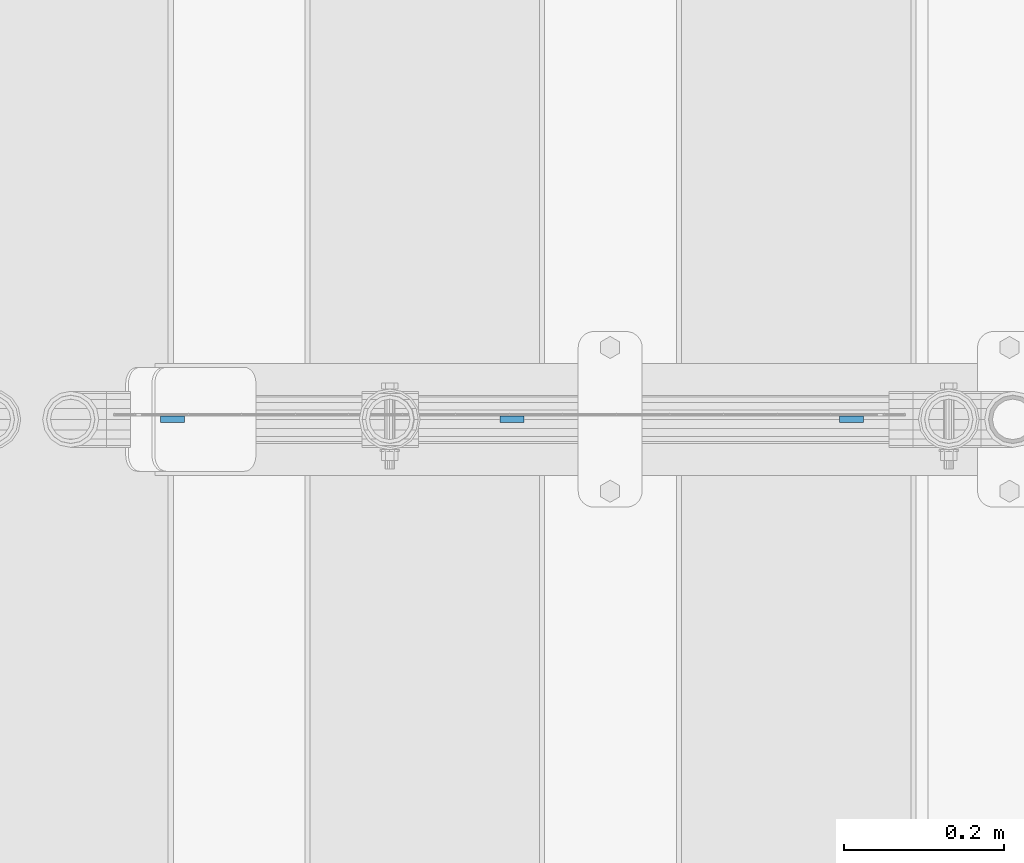
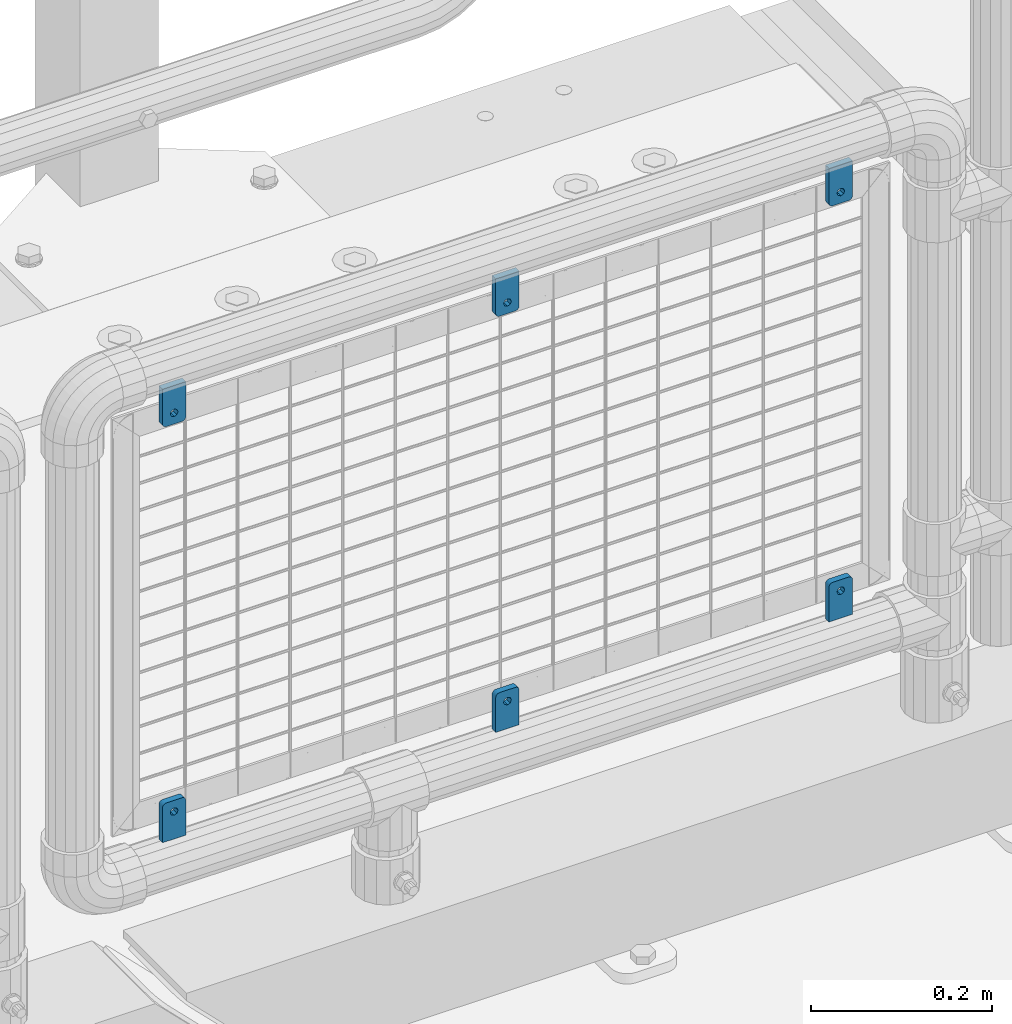
# One storey, part 244 of 247: 6 plates.
"""IFC2X3 building model written with IfcOpenShell, lengths in millimetres."""

from ifc_helpers import new_model, si_unit, frame, origin_with_axes, place, context, subcontext, project, spatial, faceted_brep, material, type_object, element, save


model = new_model("IFC2X3")

# Units and contexts
model_context = context("Model", 3, precision=1e-05, world=origin_with_axes())
body_context = subcontext(model_context, "Body", "Model", "MODEL_VIEW")
ifc_project = project(units=[si_unit("LENGTHUNIT", "METRE", prefix="MILLI"), si_unit("AREAUNIT", "SQUARE_METRE"), si_unit("VOLUMEUNIT", "CUBIC_METRE"), si_unit("MASSUNIT", "GRAM", prefix="KILO"), si_unit("TIMEUNIT", "SECOND"), si_unit("PLANEANGLEUNIT", "RADIAN"), si_unit("SOLIDANGLEUNIT", "STERADIAN"), si_unit("THERMODYNAMICTEMPERATUREUNIT", "DEGREE_CELSIUS"), si_unit("LUMINOUSINTENSITYUNIT", "LUMEN")], contexts=[model_context])

# Site, building, storey
site_placement = place(None, origin_with_axes())
site = spatial("IfcSite", under=ifc_project, at=site_placement, CompositionType="ELEMENT")
building_placement = place(site_placement, origin_with_axes())
building = spatial("IfcBuilding", under=site, at=building_placement, Name="Standard", CompositionType="ELEMENT")
storey_placement = place(building_placement, origin_with_axes())
storey = spatial("IfcBuildingStorey", under=building, at=storey_placement, Name="Undefined", CompositionType="ELEMENT", Elevation=0.0)

# Plates
ifc_material = material(Name="STEEL/S355J2")
plate_type = type_object("IfcPlateType", PredefinedType="NOTDEFINED")
plate_1_placement = place(storey_placement, frame((15689.1, 7664.49994161967, 328.320000000077), z_axis=(-1.0, 0.0, 0.0), x_axis=(0.0, 0.0, 1.0)))
element("IfcPlate", 1, at=plate_1_placement, inside=storey, type_object=plate_type, material=ifc_material, context=body_context, shape_type="Brep", body=[
    faceted_brep([(48.5450849718748, -3.99999999999909, 29.7552825814757), (49.9389262614624, -3.99999999999909, 29.0450849718746), (49.9389262614624, 4.00000000000091, 29.0450849718746), (48.5450849718748, 4.00000000000091, 29.7552825814757), (51.0450849718748, -4.0, 27.9389262614624), (51.0450849718748, 4.0, 27.9389262614623), (51.7552825814757, -4.0, 26.5450849718746), (51.7552825814757, 4.0, 26.5450849718746), (52.0, -4.0, 25.0), (52.0, 4.0, 24.9999999999999), (52.0, -4.0, 5.0), (52.0, 4.0, 4.99999999999989), (51.7552825814757, -4.0, 3.45491502812524), (51.7552825814757, 4.0, 3.45491502812524), (51.0450849718748, -4.0, 2.06107373853763), (51.0450849718748, 4.0, 2.06107373853752), (49.9389262614624, -4.0, 0.954915028125242), (49.9389262614624, 4.0, 0.954915028125242), (48.5450849718748, -4.0, 0.244717418524147), (48.5450849718748, 4.0, 0.244717418524147), (47.0, -4.0, 0.0), (47.0, 4.0, -1.13686837721616e-13), (0.0, -4.0, 0.0), (0.0, 4.0, -1.13686837721616e-13), (0.0, -3.99999999999909, 30.0), (47.0, -3.99999999999909, 30.0), (47.0, 4.00000000000091, 29.9999999999999), (0.0, 4.00000000000091, 29.9999999999999), (42.0, -4.0, 15.0000000039363), (40.5355339059328, -4.0, 11.4644660980035), (37.0, -4.0, 10.0000000039363), (33.4644660940672, -4.0, 11.4644660980035), (32.0, -4.0, 15.0000000039363), (33.4644660940672, -4.0, 18.5355339098691), (37.0, -4.0, 20.0000000039363), (40.5355339059328, -4.0, 18.5355339098691), (33.4644660940672, 4.00000000000091, 11.4644660900035), (37.0, 4.00000000000091, 9.99999999593626), (32.0, 4.00000000000091, 14.9999999959363), (33.4644660940672, 4.00000000000091, 18.535533901869), (37.0, 4.00000000000091, 19.9999999959363), (40.5355339059328, 4.00000000000091, 18.535533901869), (42.0, 4.00000000000091, 14.9999999959363), (40.5355339059328, 4.00000000000091, 11.4644660900035)], [[[0, 1, 2, 3]], [[1, 4, 5, 2]], [[4, 6, 7, 5]], [[6, 8, 9, 7]], [[8, 10, 11, 9]], [[10, 12, 13, 11]], [[12, 14, 15, 13]], [[14, 16, 17, 15]], [[16, 18, 19, 17]], [[18, 20, 21, 19]], [[20, 22, 23, 21]], [[24, 25, 26, 27]], [[22, 24, 27, 23]], [[20, 18, 16, 14, 12, 10, 8, 6, 4, 1, 0, 25, 24, 22], [28, 29, 30, 31, 32, 33, 34, 35]], [[36, 31, 30, 37]], [[38, 32, 31, 36]], [[39, 33, 32, 38]], [[40, 34, 33, 39]], [[41, 35, 34, 40]], [[42, 28, 35, 41]], [[43, 29, 28, 42]], [[37, 30, 29, 43]], [[26, 3, 2, 5, 7, 9, 11, 13, 15, 17, 19, 21, 23, 27], [38, 36, 37, 43, 42, 41, 40, 39]], [[25, 0, 3, 26]]]),
])
plate_2_placement = place(storey_placement, frame((15659.1, 7664.49994161967, 939.699999999924), z_axis=(1.0, 0.0, 0.0), x_axis=(0.0, 0.0, -1.0)))
element("IfcPlate", 2, at=plate_2_placement, inside=storey, type_object=plate_type, material=ifc_material, context=body_context, shape_type="Brep", body=[
    faceted_brep([(48.5450849718748, -3.99999999999909, 29.7552825814757), (49.9389262614624, -3.99999999999909, 29.0450849718746), (49.9389262614624, 4.00000000000091, 29.0450849718746), (48.5450849718748, 4.00000000000091, 29.7552825814757), (51.0450849718748, -4.0, 27.9389262614624), (51.0450849718748, 4.0, 27.9389262614623), (51.7552825814757, -4.0, 26.5450849718746), (51.7552825814757, 4.0, 26.5450849718746), (52.0, -4.0, 25.0), (52.0, 4.0, 24.9999999999999), (52.0, -4.0, 5.0), (52.0, 4.0, 4.99999999999989), (51.7552825814757, -4.0, 3.45491502812524), (51.7552825814757, 4.0, 3.45491502812524), (51.0450849718748, -4.0, 2.06107373853763), (51.0450849718748, 4.0, 2.06107373853752), (49.9389262614624, -4.0, 0.954915028125242), (49.9389262614624, 4.0, 0.954915028125242), (48.5450849718748, -4.0, 0.244717418524147), (48.5450849718748, 4.0, 0.244717418524147), (47.0, -4.0, 0.0), (47.0, 4.0, -1.13686837721616e-13), (0.0, -4.0, 0.0), (0.0, 4.0, -1.13686837721616e-13), (0.0, -3.99999999999909, 30.0), (47.0, -3.99999999999909, 30.0), (47.0, 4.00000000000091, 29.9999999999999), (0.0, 4.00000000000091, 29.9999999999999), (42.0, -4.0, 15.0000000039363), (40.5355339059328, -4.0, 11.4644660980035), (37.0, -4.0, 10.0000000039363), (33.4644660940672, -4.0, 11.4644660980035), (32.0, -4.0, 15.0000000039363), (33.4644660940672, -4.0, 18.5355339098691), (37.0, -4.0, 20.0000000039363), (40.5355339059328, -4.0, 18.5355339098691), (40.5355339059328, 4.00000000000091, 18.535533901869), (37.0, 4.00000000000091, 19.9999999959363), (42.0, 4.00000000000091, 14.9999999959363), (40.5355339059328, 4.00000000000091, 11.4644660900035), (37.0, 4.00000000000091, 9.99999999593626), (33.4644660940672, 4.00000000000091, 11.4644660900035), (32.0, 4.00000000000091, 14.9999999959363), (33.4644660940672, 4.00000000000091, 18.535533901869)], [[[0, 1, 2, 3]], [[1, 4, 5, 2]], [[4, 6, 7, 5]], [[6, 8, 9, 7]], [[8, 10, 11, 9]], [[10, 12, 13, 11]], [[12, 14, 15, 13]], [[14, 16, 17, 15]], [[16, 18, 19, 17]], [[18, 20, 21, 19]], [[20, 22, 23, 21]], [[24, 25, 26, 27]], [[22, 24, 27, 23]], [[20, 18, 16, 14, 12, 10, 8, 6, 4, 1, 0, 25, 24, 22], [28, 29, 30, 31, 32, 33, 34, 35]], [[36, 35, 34, 37]], [[38, 28, 35, 36]], [[39, 29, 28, 38]], [[40, 30, 29, 39]], [[41, 31, 30, 40]], [[42, 32, 31, 41]], [[43, 33, 32, 42]], [[37, 34, 33, 43]], [[26, 3, 2, 5, 7, 9, 11, 13, 15, 17, 19, 21, 23, 27], [42, 41, 40, 39, 38, 36, 37, 43]], [[25, 0, 3, 26]]]),
])
plate_3_placement = place(storey_placement, frame((15264.1, 7664.49994161967, 328.320000000077), z_axis=(-1.0, 0.0, 0.0), x_axis=(0.0, 0.0, 1.0)))
element("IfcPlate", 3, at=plate_3_placement, inside=storey, type_object=plate_type, material=ifc_material, context=body_context, shape_type="Brep", body=[
    faceted_brep([(48.5450849718748, -3.99999999999909, 29.7552825814757), (49.9389262614624, -3.99999999999909, 29.0450849718746), (49.9389262614624, 4.00000000000091, 29.0450849718746), (48.5450849718748, 4.00000000000091, 29.7552825814757), (51.0450849718748, -4.0, 27.9389262614624), (51.0450849718748, 4.0, 27.9389262614623), (51.7552825814757, -4.0, 26.5450849718746), (51.7552825814757, 4.0, 26.5450849718746), (52.0, -4.0, 25.0), (52.0, 4.0, 24.9999999999999), (52.0, -4.0, 5.0), (52.0, 4.0, 4.99999999999989), (51.7552825814757, -4.0, 3.45491502812524), (51.7552825814757, 4.0, 3.45491502812524), (51.0450849718748, -4.0, 2.06107373853763), (51.0450849718748, 4.0, 2.06107373853752), (49.9389262614624, -4.0, 0.954915028125242), (49.9389262614624, 4.0, 0.954915028125242), (48.5450849718748, -4.0, 0.244717418524147), (48.5450849718748, 4.0, 0.244717418524147), (47.0, -4.0, 0.0), (47.0, 4.0, -1.13686837721616e-13), (0.0, -4.0, 0.0), (0.0, 4.0, -1.13686837721616e-13), (0.0, -3.99999999999909, 30.0), (47.0, -3.99999999999909, 30.0), (47.0, 4.00000000000091, 29.9999999999999), (0.0, 4.00000000000091, 29.9999999999999), (42.0, -4.0, 15.0000000039363), (40.5355339059328, -4.0, 11.4644660980035), (37.0, -4.0, 10.0000000039363), (33.4644660940672, -4.0, 11.4644660980035), (32.0, -4.0, 15.0000000039363), (33.4644660940672, -4.0, 18.5355339098691), (37.0, -4.0, 20.0000000039363), (40.5355339059328, -4.0, 18.5355339098691), (33.4644660940672, 4.00000000000091, 11.4644660900035), (37.0, 4.00000000000091, 9.99999999593626), (32.0, 4.00000000000091, 14.9999999959363), (33.4644660940672, 4.00000000000091, 18.535533901869), (37.0, 4.00000000000091, 19.9999999959363), (40.5355339059328, 4.00000000000091, 18.535533901869), (42.0, 4.00000000000091, 14.9999999959363), (40.5355339059328, 4.00000000000091, 11.4644660900035)], [[[0, 1, 2, 3]], [[1, 4, 5, 2]], [[4, 6, 7, 5]], [[6, 8, 9, 7]], [[8, 10, 11, 9]], [[10, 12, 13, 11]], [[12, 14, 15, 13]], [[14, 16, 17, 15]], [[16, 18, 19, 17]], [[18, 20, 21, 19]], [[20, 22, 23, 21]], [[24, 25, 26, 27]], [[22, 24, 27, 23]], [[20, 18, 16, 14, 12, 10, 8, 6, 4, 1, 0, 25, 24, 22], [28, 29, 30, 31, 32, 33, 34, 35]], [[36, 31, 30, 37]], [[38, 32, 31, 36]], [[39, 33, 32, 38]], [[40, 34, 33, 39]], [[41, 35, 34, 40]], [[42, 28, 35, 41]], [[43, 29, 28, 42]], [[37, 30, 29, 43]], [[26, 3, 2, 5, 7, 9, 11, 13, 15, 17, 19, 21, 23, 27], [38, 36, 37, 43, 42, 41, 40, 39]], [[25, 0, 3, 26]]]),
])
plate_4_placement = place(storey_placement, frame((15234.1, 7664.49994161967, 939.699999999924), z_axis=(1.0, 0.0, 0.0), x_axis=(0.0, 0.0, -1.0)))
element("IfcPlate", 4, at=plate_4_placement, inside=storey, type_object=plate_type, material=ifc_material, context=body_context, shape_type="Brep", body=[
    faceted_brep([(48.5450849718748, -3.99999999999909, 29.7552825814757), (49.9389262614624, -3.99999999999909, 29.0450849718746), (49.9389262614624, 4.00000000000091, 29.0450849718746), (48.5450849718748, 4.00000000000091, 29.7552825814757), (51.0450849718748, -4.0, 27.9389262614624), (51.0450849718748, 4.0, 27.9389262614623), (51.7552825814757, -4.0, 26.5450849718746), (51.7552825814757, 4.0, 26.5450849718746), (52.0, -4.0, 25.0), (52.0, 4.0, 24.9999999999999), (52.0, -4.0, 5.0), (52.0, 4.0, 4.99999999999989), (51.7552825814757, -4.0, 3.45491502812524), (51.7552825814757, 4.0, 3.45491502812524), (51.0450849718748, -4.0, 2.06107373853763), (51.0450849718748, 4.0, 2.06107373853752), (49.9389262614624, -4.0, 0.954915028125242), (49.9389262614624, 4.0, 0.954915028125242), (48.5450849718748, -4.0, 0.244717418524147), (48.5450849718748, 4.0, 0.244717418524147), (47.0, -4.0, 0.0), (47.0, 4.0, -1.13686837721616e-13), (0.0, -4.0, 0.0), (0.0, 4.0, -1.13686837721616e-13), (0.0, -3.99999999999909, 30.0), (47.0, -3.99999999999909, 30.0), (47.0, 4.00000000000091, 29.9999999999999), (0.0, 4.00000000000091, 29.9999999999999), (42.0, -4.0, 15.0000000039363), (40.5355339059328, -4.0, 11.4644660980035), (37.0, -4.0, 10.0000000039363), (33.4644660940672, -4.0, 11.4644660980035), (32.0, -4.0, 15.0000000039363), (33.4644660940672, -4.0, 18.5355339098691), (37.0, -4.0, 20.0000000039363), (40.5355339059328, -4.0, 18.5355339098691), (40.5355339059328, 4.00000000000091, 18.535533901869), (37.0, 4.00000000000091, 19.9999999959363), (42.0, 4.00000000000091, 14.9999999959363), (40.5355339059328, 4.00000000000091, 11.4644660900035), (37.0, 4.00000000000091, 9.99999999593626), (33.4644660940672, 4.00000000000091, 11.4644660900035), (32.0, 4.00000000000091, 14.9999999959363), (33.4644660940672, 4.00000000000091, 18.535533901869)], [[[0, 1, 2, 3]], [[1, 4, 5, 2]], [[4, 6, 7, 5]], [[6, 8, 9, 7]], [[8, 10, 11, 9]], [[10, 12, 13, 11]], [[12, 14, 15, 13]], [[14, 16, 17, 15]], [[16, 18, 19, 17]], [[18, 20, 21, 19]], [[20, 22, 23, 21]], [[24, 25, 26, 27]], [[22, 24, 27, 23]], [[20, 18, 16, 14, 12, 10, 8, 6, 4, 1, 0, 25, 24, 22], [28, 29, 30, 31, 32, 33, 34, 35]], [[36, 35, 34, 37]], [[38, 28, 35, 36]], [[39, 29, 28, 38]], [[40, 30, 29, 39]], [[41, 31, 30, 40]], [[42, 32, 31, 41]], [[43, 33, 32, 42]], [[37, 34, 33, 43]], [[26, 3, 2, 5, 7, 9, 11, 13, 15, 17, 19, 21, 23, 27], [42, 41, 40, 39, 38, 36, 37, 43]], [[25, 0, 3, 26]]]),
])
plate_5_placement = place(storey_placement, frame((16114.1, 7664.49994161967, 328.320000000077), z_axis=(-1.0, 0.0, 0.0), x_axis=(0.0, 0.0, 1.0)))
element("IfcPlate", 5, at=plate_5_placement, inside=storey, type_object=plate_type, material=ifc_material, context=body_context, shape_type="Brep", body=[
    faceted_brep([(48.5450849718748, -3.99999999999909, 29.7552825814757), (49.9389262614624, -3.99999999999909, 29.0450849718746), (49.9389262614624, 4.00000000000091, 29.0450849718746), (48.5450849718748, 4.00000000000091, 29.7552825814757), (51.0450849718748, -4.0, 27.9389262614624), (51.0450849718748, 4.0, 27.9389262614623), (51.7552825814757, -4.0, 26.5450849718746), (51.7552825814757, 4.0, 26.5450849718746), (52.0, -4.0, 25.0), (52.0, 4.0, 24.9999999999999), (52.0, -4.0, 5.0), (52.0, 4.0, 4.99999999999989), (51.7552825814757, -4.0, 3.45491502812524), (51.7552825814757, 4.0, 3.45491502812524), (51.0450849718748, -4.0, 2.06107373853763), (51.0450849718748, 4.0, 2.06107373853752), (49.9389262614624, -4.0, 0.954915028125242), (49.9389262614624, 4.0, 0.954915028125242), (48.5450849718748, -4.0, 0.244717418524147), (48.5450849718748, 4.0, 0.244717418524147), (47.0, -4.0, 0.0), (47.0, 4.0, -1.13686837721616e-13), (0.0, -4.0, 0.0), (0.0, 4.0, -1.13686837721616e-13), (0.0, -3.99999999999909, 30.0), (47.0, -3.99999999999909, 30.0), (47.0, 4.00000000000091, 29.9999999999999), (0.0, 4.00000000000091, 29.9999999999999), (42.0, -4.0, 15.0000000039363), (40.5355339059328, -4.0, 11.4644660980035), (37.0, -4.0, 10.0000000039363), (33.4644660940672, -4.0, 11.4644660980035), (32.0, -4.0, 15.0000000039363), (33.4644660940672, -4.0, 18.5355339098691), (37.0, -4.0, 20.0000000039363), (40.5355339059328, -4.0, 18.5355339098691), (33.4644660940672, 4.00000000000091, 11.4644660900035), (37.0, 4.00000000000091, 9.99999999593626), (32.0, 4.00000000000091, 14.9999999959363), (33.4644660940672, 4.00000000000091, 18.535533901869), (37.0, 4.00000000000091, 19.9999999959363), (40.5355339059328, 4.00000000000091, 18.535533901869), (42.0, 4.00000000000091, 14.9999999959363), (40.5355339059328, 4.00000000000091, 11.4644660900035)], [[[0, 1, 2, 3]], [[1, 4, 5, 2]], [[4, 6, 7, 5]], [[6, 8, 9, 7]], [[8, 10, 11, 9]], [[10, 12, 13, 11]], [[12, 14, 15, 13]], [[14, 16, 17, 15]], [[16, 18, 19, 17]], [[18, 20, 21, 19]], [[20, 22, 23, 21]], [[24, 25, 26, 27]], [[22, 24, 27, 23]], [[20, 18, 16, 14, 12, 10, 8, 6, 4, 1, 0, 25, 24, 22], [28, 29, 30, 31, 32, 33, 34, 35]], [[36, 31, 30, 37]], [[38, 32, 31, 36]], [[39, 33, 32, 38]], [[40, 34, 33, 39]], [[41, 35, 34, 40]], [[42, 28, 35, 41]], [[43, 29, 28, 42]], [[37, 30, 29, 43]], [[26, 3, 2, 5, 7, 9, 11, 13, 15, 17, 19, 21, 23, 27], [38, 36, 37, 43, 42, 41, 40, 39]], [[25, 0, 3, 26]]]),
])
plate_6_placement = place(storey_placement, frame((16084.1, 7664.49994161967, 939.699999999924), z_axis=(1.0, 0.0, 0.0), x_axis=(0.0, 0.0, -1.0)))
element("IfcPlate", 6, at=plate_6_placement, inside=storey, type_object=plate_type, material=ifc_material, context=body_context, shape_type="Brep", body=[
    faceted_brep([(48.5450849718748, -3.99999999999909, 29.7552825814757), (49.9389262614624, -3.99999999999909, 29.0450849718746), (49.9389262614624, 4.00000000000091, 29.0450849718746), (48.5450849718748, 4.00000000000091, 29.7552825814757), (51.0450849718748, -4.0, 27.9389262614624), (51.0450849718748, 4.0, 27.9389262614623), (51.7552825814757, -4.0, 26.5450849718746), (51.7552825814757, 4.0, 26.5450849718746), (52.0, -4.0, 25.0), (52.0, 4.0, 24.9999999999999), (52.0, -4.0, 5.0), (52.0, 4.0, 4.99999999999989), (51.7552825814757, -4.0, 3.45491502812524), (51.7552825814757, 4.0, 3.45491502812524), (51.0450849718748, -4.0, 2.06107373853763), (51.0450849718748, 4.0, 2.06107373853752), (49.9389262614624, -4.0, 0.954915028125242), (49.9389262614624, 4.0, 0.954915028125242), (48.5450849718748, -4.0, 0.244717418524147), (48.5450849718748, 4.0, 0.244717418524147), (47.0, -4.0, 0.0), (47.0, 4.0, -1.13686837721616e-13), (0.0, -4.0, 0.0), (0.0, 4.0, -1.13686837721616e-13), (0.0, -3.99999999999909, 30.0), (47.0, -3.99999999999909, 30.0), (47.0, 4.00000000000091, 29.9999999999999), (0.0, 4.00000000000091, 29.9999999999999), (42.0, -4.0, 15.0000000039363), (40.5355339059328, -4.0, 11.4644660980035), (37.0, -4.0, 10.0000000039363), (33.4644660940672, -4.0, 11.4644660980035), (32.0, -4.0, 15.0000000039363), (33.4644660940672, -4.0, 18.5355339098691), (37.0, -4.0, 20.0000000039363), (40.5355339059328, -4.0, 18.5355339098691), (40.5355339059328, 4.00000000000091, 18.535533901869), (37.0, 4.00000000000091, 19.9999999959363), (42.0, 4.00000000000091, 14.9999999959363), (40.5355339059328, 4.00000000000091, 11.4644660900035), (37.0, 4.00000000000091, 9.99999999593626), (33.4644660940672, 4.00000000000091, 11.4644660900035), (32.0, 4.00000000000091, 14.9999999959363), (33.4644660940672, 4.00000000000091, 18.535533901869)], [[[0, 1, 2, 3]], [[1, 4, 5, 2]], [[4, 6, 7, 5]], [[6, 8, 9, 7]], [[8, 10, 11, 9]], [[10, 12, 13, 11]], [[12, 14, 15, 13]], [[14, 16, 17, 15]], [[16, 18, 19, 17]], [[18, 20, 21, 19]], [[20, 22, 23, 21]], [[24, 25, 26, 27]], [[22, 24, 27, 23]], [[20, 18, 16, 14, 12, 10, 8, 6, 4, 1, 0, 25, 24, 22], [28, 29, 30, 31, 32, 33, 34, 35]], [[36, 35, 34, 37]], [[38, 28, 35, 36]], [[39, 29, 28, 38]], [[40, 30, 29, 39]], [[41, 31, 30, 40]], [[42, 32, 31, 41]], [[43, 33, 32, 42]], [[37, 34, 33, 43]], [[26, 3, 2, 5, 7, 9, 11, 13, 15, 17, 19, 21, 23, 27], [42, 41, 40, 39, 38, 36, 37, 43]], [[25, 0, 3, 26]]]),
])

save(model, "model.ifc")
